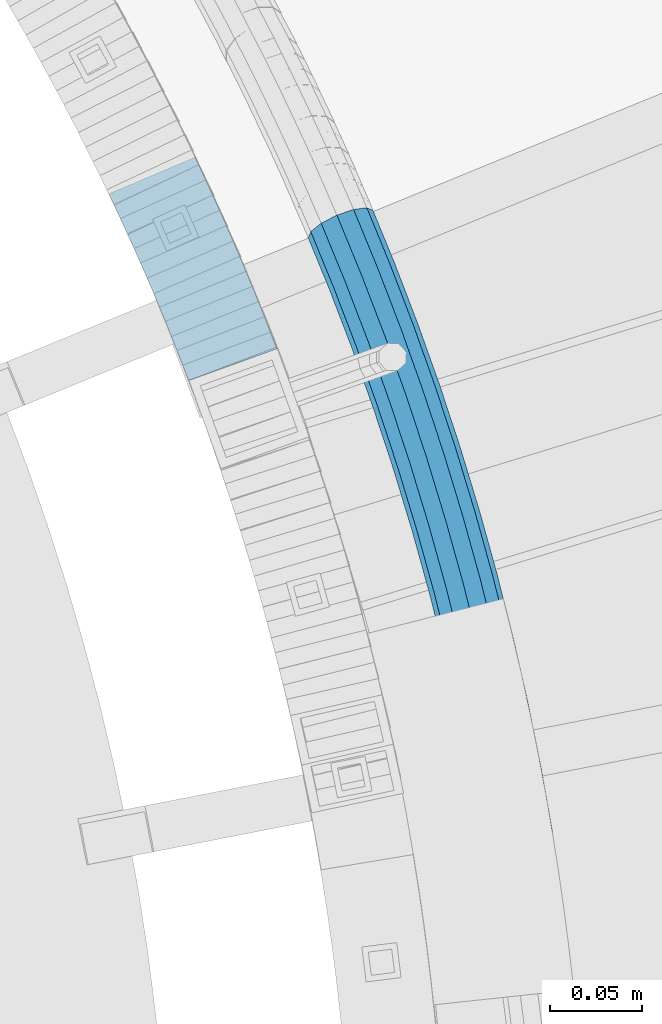
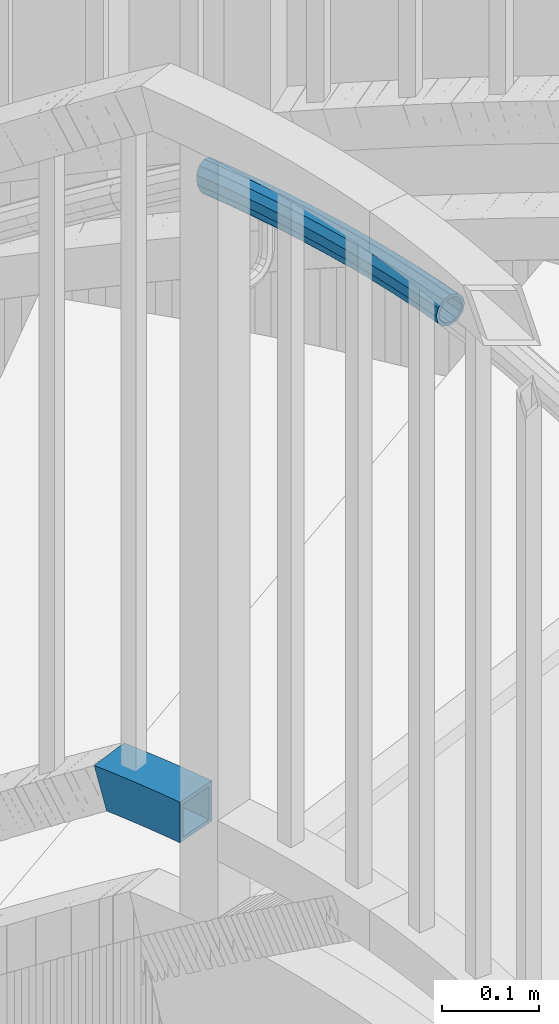
# One storey, part 502 of 975: 2 beams.
"""IFC2X3 building model written with IfcOpenShell, lengths in millimetres."""

from ifc_helpers import new_model, si_unit, frame, origin_with_axes, place, context, subcontext, project, spatial, faceted_brep, material, type_object, element, save


model = new_model("IFC2X3")

# Units and contexts
model_context = context("Model", 3, precision=1e-05, world=origin_with_axes())
body_context = subcontext(model_context, "Body", "Model", "MODEL_VIEW")
ifc_project = project(units=[si_unit("LENGTHUNIT", "METRE", prefix="MILLI"), si_unit("AREAUNIT", "SQUARE_METRE"), si_unit("VOLUMEUNIT", "CUBIC_METRE"), si_unit("MASSUNIT", "GRAM", prefix="KILO"), si_unit("TIMEUNIT", "SECOND"), si_unit("PLANEANGLEUNIT", "RADIAN"), si_unit("SOLIDANGLEUNIT", "STERADIAN"), si_unit("THERMODYNAMICTEMPERATUREUNIT", "DEGREE_CELSIUS"), si_unit("LUMINOUSINTENSITYUNIT", "LUMEN")], contexts=[model_context])

# Site, building, storey
site_placement = place(None, origin_with_axes())
site = spatial("IfcSite", under=ifc_project, at=site_placement, CompositionType="ELEMENT")
building_placement = place(site_placement, origin_with_axes())
building = spatial("IfcBuilding", under=site, at=building_placement, Name="Undefined", CompositionType="ELEMENT")
storey_placement = place(building_placement, origin_with_axes())
storey = spatial("IfcBuildingStorey", under=building, at=storey_placement, Name="Undefined", CompositionType="ELEMENT", Elevation=0.0)

# Beams
ifc_material = material()
beam_type_1 = type_object("IfcBeamType", PredefinedType="NOTDEFINED")
beam_1_placement = place(storey_placement, frame((36096.268932607, 3982.0925191272, 3028.95), z_axis=(0.0, 0.0, 1.0), x_axis=(0.279148057079959, -0.96024807327507, 0.0)))
element("IfcBeam", 1, at=beam_1_placement, inside=storey, type_object=beam_type_1, material=ifc_material, Name="HANDRAIL", context=body_context, shape_type="Brep", body=[
    faceted_brep([(33.3876668180537, 20.1749225351741, -9.52500000000009), (34.0493773826274, 13.2336074557752, -16.4977839420935), (8.77800632553954, 10.5211892533189, -16.4977839420935), (6.00829838439677, 17.2362494753179, -9.52500000000009), (33.1454639414678, 22.7156201899052, 0.0), (3.05124445357887, 19.4855576601331, 0.0), (33.3876668180537, 20.1749225351741, 9.52500000000009), (0.699184745821185, 16.6664134961102, 9.52500000000009), (34.0493773826274, 13.2336074557752, 16.4977839420935), (-0.41764823963058, 9.5342043853525, 16.4977839420935), (34.9532908237879, 3.75159472163068, 19.0500000000002), (-3.63797880709171e-12, 3.63797880709171e-12, 19.0500000000002), (35.8572042649494, -5.73041801250656, 16.4977839420935), (1.84022093912063, -9.38151729624224, 16.4977839420935), (36.5189148295231, -12.6717330918982, 9.52500000000009), (4.60992888025976, -16.0965775182485, 9.52500000000009), (36.761117706109, -15.2124307466365, 0.0), (7.56698281107674, -18.3458857030564, 0.0), (36.5189148295231, -12.6717330918982, -9.52500000000009), (9.91904251883534, -15.5267415390408, -9.52500000000009), (35.8572042649494, -5.73041801250656, -16.4977839420935), (11.0358755042871, -8.39453242827585, -16.4977839420935), (34.9532908237879, 3.75159472163068, -19.0500000000002), (10.618227270902, 1.13967195773876, -19.0500000000002), (69.3074649391092, 16.1725120505725, -16.4977839420935), (69.9858469033625, 6.67170035314484, -19.0500000000002), (70.6642288676157, -2.82911134429742, -16.4977839420935), (71.1608389323883, -9.78418821995729, -9.52500000000009), (71.3426108318708, -12.3299230417178, 0.0), (71.1608389323883, -9.78418821995729, 9.52500000000009), (70.6642288676157, -2.82911134429742, 16.4977839420935), (69.9858469033625, 6.67170035314484, 19.0500000000002), (69.3074649391092, 16.1725120505725, 16.4977839420935), (68.8108548743385, 23.1275889262324, 9.52500000000009), (68.6290829748559, 25.6733237480003, 0.0), (68.8108548743385, 23.1275889262324, -9.52500000000009), (104.294194385069, 25.2378277880198, -9.52500000000009), (104.625423595964, 18.2729155048291, -16.4977839420935), (105.077891112518, 8.75866839083756, -19.0500000000002), (105.530358629074, -0.755578723139479, -16.4977839420935), (105.861587839967, -7.72049100634467, -9.52500000000009), (105.982826145628, -10.2698258371238, 0.0), (105.861587839967, -7.72049100634467, 9.52500000000009), (105.530358629074, -0.755578723139479, 16.4977839420935), (105.077891112518, 8.75866839083756, 19.0500000000002), (104.625423595964, 18.2729155048291, 16.4977839420935), (104.29419438507, 25.2378277880198, 9.52500000000009), (104.172956079408, 27.7871626187989, 0.0), (139.757017472239, 29.0559434649622, 0.0), (139.817653740735, 26.5044478155105, -9.52500000000009), (139.983315107059, 19.5336320659408, -16.4977839420935), (140.209612741879, 10.0113206669193, -19.0500000000002), (140.435910376701, 0.489009267897927, -16.4977839420935), (140.601571743023, -6.48180648167909, -9.52500000000009), (140.662208011521, -9.03330213112349, 0.0), (140.601571743023, -6.48180648167909, 9.52500000000009), (140.435910376701, 0.489009267897927, 16.4977839420935), (140.209612741879, 10.0113206669193, 19.0500000000002), (139.983315107059, 19.5336320659408, 16.4977839420935), (139.817653740735, 26.5044478155105, 9.52500000000009), (175.361178682741, 26.9267339565704, 9.52500000000009), (175.361178682739, 29.4789500144689, 0.0), (175.361178682741, 26.9267339565704, -9.52500000000009), (175.361178682746, 19.9539500144965, -16.4977839420935), (175.361178682757, 10.4289500145242, -19.0500000000002), (175.361178682763, 0.90395001455181, -16.4977839420935), (175.361178682768, -6.06883392752206, -9.52500000000009), (175.361178682771, -8.62104998542054, 0.0), (175.361178682768, -6.06883392752206, 9.52500000000009), (175.361178682763, 0.90395001455181, 16.4977839420935), (175.361178682757, 10.4289500145242, 19.0500000000002), (175.361178682746, 19.9539500144965, 16.4977839420935), (210.739042258436, 19.5336320660281, 16.4977839420935), (210.904703624745, 26.5044478156051, 9.52500000000009), (210.965339893238, 29.0559434650495, 0.0), (210.904703624745, 26.5044478156051, -9.52500000000009), (210.739042258436, 19.5336320660281, -16.4977839420935), (210.512744623631, 10.0113206670139, -19.0500000000002), (210.286446988826, 0.489009267985239, -16.4977839420935), (210.120785622517, -6.48180648159178, -9.52500000000009), (210.060149354023, -9.03330213103618, 0.0), (210.120785622517, -6.48180648159178, 9.52500000000009), (210.286446988826, 0.489009267985239, 16.4977839420935), (210.512744623631, 10.0113206670139, 19.0500000000002), (245.644466252994, 8.75866839102673, 19.0500000000002), (246.096933769533, 18.272915505011, 16.4977839420935), (246.428162980414, 25.237827788209, 9.52500000000009), (246.549401286071, 27.7871626189954, 0.0), (246.428162980414, 25.237827788209, -9.52500000000009), (246.096933769533, 18.272915505011, -16.4977839420935), (245.644466252994, 8.75866839102673, -19.0500000000002), (245.191998736456, -0.75557872295758, -16.4977839420935), (244.860769525577, -7.7204910061555, -9.52500000000009), (244.739531219917, -10.2698258369419, 0.0), (244.860769525577, -7.7204910061555, 9.52500000000009), (245.191998736456, -0.75557872295758, 16.4977839420935), (280.058128497918, -2.82911134402093, 16.4977839420935), (280.736510462153, 6.67170035342133, 19.0500000000002), (281.41489242639, 16.1725120508418, 16.4977839420935), (281.911502491151, 23.1275889265089, 9.52500000000009), (282.093274390627, 25.673323748284, 0.0), (281.911502491151, 23.1275889265089, -9.52500000000009), (281.41489242639, 16.1725120508418, -16.4977839420935), (280.736510462153, 6.67170035342133, -19.0500000000002), (280.058128497918, -2.82911134402093, -16.4977839420935), (279.561518433156, -9.78418821968808, -9.52500000000009), (279.379746533681, -12.3299230414414, 0.0), (279.561518433156, -9.78418821968808, 9.52500000000009), (314.203442536028, -12.671733091549, 9.52500000000009), (314.865153100589, -5.73041801214276, 16.4977839420935), (315.769066541734, 3.75159472200176, 19.0500000000002), (316.672979982877, 13.2336074561463, 16.4977839420935), (317.334690547441, 20.1749225355452, 9.52500000000009), (317.57689342402, 22.7156201902762, 0.0), (317.334690547441, 20.1749225355452, -9.52500000000009), (316.672979982877, 13.2336074561463, -16.4977839420935), (315.769066541734, 3.75159472200176, -19.0500000000002), (314.865153100589, -5.73041801214276, -16.4977839420935), (314.203442536028, -12.671733091549, -9.52500000000009), (313.961239659444, -15.2124307462873, 0.0), (348.464488112119, -18.9157216731255, 0.0), (348.766985233651, -16.3814954997797, 9.52500000000009), (349.593422738822, -9.45786083632993, 16.4977839420935), (350.722357365528, 4.58385329693556e-10, 19.0500000000002), (351.851291992232, 9.4578608372467, 16.4977839420935), (352.677729497404, 16.3814955006965, 9.52500000000009), (352.980226618936, 18.9157216740423, 0.0), (352.677729497404, 16.3814955006965, -9.52500000000009), (351.851291992231, 9.4578608372467, -16.4977839420935), (350.722357365528, 4.58385329693556e-10, -19.0500000000002), (349.593422738822, -9.45786083632993, -16.4977839420935), (348.766985233651, -16.3814954997797, -9.52500000000009), (36.2162275217488, -9.49655638128752, -7.68350000000009), (36.4116045088613, -11.5460524894443, 0.0), (71.0803031390251, -8.65627585204493, 0.0), (70.9336738067759, -6.60271642915177, -7.68350000000009), (105.807872039227, -6.59098361971701, 0.0), (105.710073139326, -4.53452018955431, -7.68350000000009), (140.574706259393, -5.35134172350081, 0.0), (140.525793002802, -3.29313523294695, -7.68350000000009), (175.36117868277, -4.93804998542328, 0.0), (175.361178682766, -2.87926236540079, -7.68350000000009), (210.147651106146, -5.3513417234135, 0.0), (210.196564362732, -3.29313523285964, -7.68350000000009), (244.914485326313, -6.59098361953511, 0.0), (245.01228422621, -4.53452018937242, -7.68350000000009), (279.642054226517, -8.65627585177572, 0.0), (279.788683558763, -6.60271642888983, -7.68350000000009), (314.506129843799, -9.49655638092372, -7.68350000000009), (314.310752856687, -11.5460524890805, 0.0), (348.901009501111, -15.2586821495643, 0.0), (349.145023845813, -13.2144063697342, -7.68350000000009), (279.788683558763, -6.60271642888983, 7.68350000000009), (314.506129843799, -9.49655638092372, 7.68350000000009), (245.01228422621, -4.53452018937242, 7.68350000000009), (210.196564362732, -3.29313523285964, 7.68350000000009), (175.361178682766, -2.87926236540079, 7.68350000000009), (140.525793002802, -3.29313523294695, 7.68350000000009), (105.710073139326, -4.53452018955431, 7.68350000000009), (70.9336738067759, -6.60271642915177, 7.68350000000009), (36.2162275217488, -9.49655638128752, 7.68350000000009), (35.682447666326, -3.89722888389952, 13.3082123799554), (70.5330750211942, -0.992287749453681, 13.3082123799554), (105.442881575875, 1.08384238556027, 13.3082123799554), (140.392159500636, 2.32998947170563, 13.3082123799554), (175.361178682762, 2.7454500145468, 13.3082123799554), (210.330197864889, 2.32998947180022, 13.3082123799554), (245.279475789652, 1.08384238574217, 13.3082123799554), (280.189282344336, -0.99228774918447, 13.3082123799554), (315.039909699211, -3.89722888353572, 13.3082123799554), (280.736510462153, 6.67170035342133, 15.3670000000002), (315.769066541734, 3.75159472200176, 15.3670000000002), (245.644466252994, 8.75866839102673, 15.3670000000002), (210.512744623631, 10.0113206670139, 15.3670000000002), (175.361178682757, 10.4289500145242, 15.3670000000002), (140.209612741879, 10.0113206669193, 15.3670000000002), (105.077891112518, 8.75866839083756, 15.3670000000002), (69.9858469033625, 6.67170035314484, 15.3670000000002), (34.9532908237879, 3.75159472163068, 15.3670000000002), (34.2241339812535, 11.4004183271682, 13.3082123799554), (69.4386187855343, 14.3356884557361, 13.3082123799554), (104.712900649164, 16.4334943961221, 13.3082123799554), (140.027065983124, 17.6926518621258, 13.3082123799554), (175.361178682748, 18.1124500145015, 13.3082123799554), (210.695291382372, 17.6926518622131, 13.3082123799554), (246.009456716336, 16.433494396304, 13.3082123799554), (281.28373857997, 14.3356884560126, 13.3082123799554), (316.498223384257, 11.4004183275392, 13.3082123799554), (281.684337365545, 19.9461171357179, 7.68350000000009), (317.032003239669, 16.99974582492, 7.68350000000009), (246.276648279781, 22.0518569714259, 7.68350000000009), (210.828924884528, 23.3157765668802, 7.68350000000009), (175.361178682743, 23.7371623944346, 7.68350000000009), (139.893432480958, 23.3157765667856, 7.68350000000009), (104.44570908571, 22.0518569712367, 7.68350000000009), (69.038019999949, 19.9461171354342, 7.68350000000009), (33.6903541258307, 16.9997458245562, 7.68350000000009), (33.4949771387164, 19.0492419327129, 0.0), (68.8913906677008, 21.9996765583273, 0.0), (104.34791018581, 24.1083204013921, 0.0), (139.844519224369, 25.3739830573395, 0.0), (175.361178682741, 25.7959500144716, 0.0), (210.877838141114, 25.3739830574268, 0.0), (246.374447179676, 24.1083204015886, 0.0), (281.830966697788, 21.9996765586038, 0.0), (317.227380226779, 19.0492419330767, 0.0), (281.684337365545, 19.9461171357179, -7.68350000000009), (317.032003239669, 16.99974582492, -7.68350000000009), (246.276648279781, 22.0518569714259, -7.68350000000009), (210.828924884528, 23.3157765668802, -7.68350000000009), (175.361178682743, 23.7371623944346, -7.68350000000009), (139.893432480958, 23.3157765667856, -7.68350000000009), (104.44570908571, 22.0518569712367, -7.68350000000009), (69.038019999949, 19.9461171354342, -7.68350000000009), (33.6903541258307, 16.9997458245562, -7.68350000000009), (34.2241339812535, 11.4004183271682, -13.3082123799554), (69.4386187855343, 14.3356884557361, -13.3082123799554), (104.712900649164, 16.4334943961221, -13.3082123799554), (140.027065983124, 17.6926518621258, -13.3082123799554), (175.361178682748, 18.1124500145015, -13.3082123799554), (210.695291382372, 17.6926518622131, -13.3082123799554), (246.009456716336, 16.433494396304, -13.3082123799554), (281.28373857997, 14.3356884560126, -13.3082123799554), (316.498223384257, 11.4004183275392, -13.3082123799554), (280.736510462153, 6.67170035342133, -15.3670000000002), (315.769066541734, 3.75159472200176, -15.3670000000002), (245.644466252994, 8.75866839102673, -15.3670000000002), (210.512744623631, 10.0113206670139, -15.3670000000002), (175.361178682757, 10.4289500145242, -15.3670000000002), (140.209612741879, 10.0113206669193, -15.3670000000002), (105.077891112518, 8.75866839083756, -15.3670000000002), (69.9858469033625, 6.67170035314484, -15.3670000000002), (34.9532908237879, 3.75159472163068, -15.3670000000002), (35.682447666326, -3.89722888389952, -13.3082123799554), (70.5330750211942, -0.992287749453681, -13.3082123799554), (105.442881575875, 1.08384238556027, -13.3082123799554), (140.392159500636, 2.32998947170563, -13.3082123799554), (175.361178682762, 2.7454500145468, -13.3082123799554), (210.330197864889, 2.32998947180022, -13.3082123799554), (245.279475789652, 1.08384238574217, -13.3082123799554), (280.189282344336, -0.99228774918447, -13.3082123799554), (315.039909699211, -3.89722888353572, -13.3082123799554), (349.81168343332, -7.6293410745493, -13.3082123799554), (350.722357365528, 4.58385329693556e-10, -15.3670000000002), (351.633031297737, 7.62934107546607, -13.3082123799554), (352.299690885242, 13.214406370651, -7.68350000000009), (352.543705229946, 15.258682150481, 0.0), (352.299690885242, 13.214406370651, 7.68350000000009), (351.633031297737, 7.62934107546607, 13.3082123799554), (350.722357365528, 4.58385329693556e-10, 15.3670000000002), (349.81168343332, -7.6293410745493, 13.3082123799554), (349.145023845813, -13.2144063697342, 7.68350000000009), (9.92870154237517, -6.66142120295262, -13.3082123799554), (9.0277896007774, -12.4147365523095, -7.68350000000009), (7.13046143651991, -14.6888461779454, 0.0), (4.74510459899466, -12.8744042421968, 7.68350000000009), (2.51087352647119, -7.45758899645443, 13.3082123799554), (1.02642863054643, 0.110168288651039, 15.3670000000002), (0.689525722282269, 7.80109316002927, 13.3082123799554), (1.59043766387913, 13.5544085093788, 7.68350000000009), (3.48776582813844, 15.828518135022, 0.0), (5.8731226656646, 14.0140761992734, -7.68350000000009), (8.10735373818534, 8.5972609535238, -13.3082123799554), (9.59179863411191, 1.02950366843288, -15.3670000000002)], [[[0, 1, 2, 3]], [[4, 0, 3, 5]], [[6, 4, 5, 7]], [[8, 6, 7, 9]], [[10, 8, 9, 11]], [[12, 10, 11, 13]], [[14, 12, 13, 15]], [[16, 14, 15, 17]], [[18, 16, 17, 19]], [[20, 18, 19, 21]], [[22, 20, 21, 23]], [[1, 22, 23, 2]], [[22, 1, 24, 25]], [[20, 22, 25, 26]], [[18, 20, 26, 27]], [[16, 18, 27, 28]], [[14, 16, 28, 29]], [[12, 14, 29, 30]], [[10, 12, 30, 31]], [[8, 10, 31, 32]], [[6, 8, 32, 33]], [[4, 6, 33, 34]], [[0, 4, 34, 35]], [[1, 0, 35, 24]], [[24, 35, 36, 37]], [[25, 24, 37, 38]], [[26, 25, 38, 39]], [[27, 26, 39, 40]], [[28, 27, 40, 41]], [[29, 28, 41, 42]], [[30, 29, 42, 43]], [[31, 30, 43, 44]], [[32, 31, 44, 45]], [[33, 32, 45, 46]], [[34, 33, 46, 47]], [[35, 34, 47, 36]], [[36, 47, 48, 49]], [[37, 36, 49, 50]], [[38, 37, 50, 51]], [[39, 38, 51, 52]], [[40, 39, 52, 53]], [[41, 40, 53, 54]], [[42, 41, 54, 55]], [[43, 42, 55, 56]], [[44, 43, 56, 57]], [[45, 44, 57, 58]], [[46, 45, 58, 59]], [[47, 46, 59, 48]], [[48, 59, 60, 61]], [[49, 48, 61, 62]], [[50, 49, 62, 63]], [[51, 50, 63, 64]], [[52, 51, 64, 65]], [[53, 52, 65, 66]], [[54, 53, 66, 67]], [[55, 54, 67, 68]], [[56, 55, 68, 69]], [[57, 56, 69, 70]], [[58, 57, 70, 71]], [[59, 58, 71, 60]], [[60, 71, 72, 73]], [[61, 60, 73, 74]], [[62, 61, 74, 75]], [[63, 62, 75, 76]], [[64, 63, 76, 77]], [[65, 64, 77, 78]], [[66, 65, 78, 79]], [[67, 66, 79, 80]], [[68, 67, 80, 81]], [[69, 68, 81, 82]], [[70, 69, 82, 83]], [[71, 70, 83, 72]], [[72, 83, 84, 85]], [[73, 72, 85, 86]], [[74, 73, 86, 87]], [[75, 74, 87, 88]], [[76, 75, 88, 89]], [[77, 76, 89, 90]], [[78, 77, 90, 91]], [[79, 78, 91, 92]], [[80, 79, 92, 93]], [[81, 80, 93, 94]], [[82, 81, 94, 95]], [[83, 82, 95, 84]], [[84, 95, 96, 97]], [[85, 84, 97, 98]], [[86, 85, 98, 99]], [[87, 86, 99, 100]], [[88, 87, 100, 101]], [[89, 88, 101, 102]], [[90, 89, 102, 103]], [[91, 90, 103, 104]], [[92, 91, 104, 105]], [[93, 92, 105, 106]], [[94, 93, 106, 107]], [[95, 94, 107, 96]], [[96, 107, 108, 109]], [[97, 96, 109, 110]], [[98, 97, 110, 111]], [[99, 98, 111, 112]], [[100, 99, 112, 113]], [[101, 100, 113, 114]], [[102, 101, 114, 115]], [[103, 102, 115, 116]], [[104, 103, 116, 117]], [[105, 104, 117, 118]], [[106, 105, 118, 119]], [[107, 106, 119, 108]], [[108, 119, 120, 121]], [[109, 108, 121, 122]], [[110, 109, 122, 123]], [[111, 110, 123, 124]], [[112, 111, 124, 125]], [[113, 112, 125, 126]], [[114, 113, 126, 127]], [[115, 114, 127, 128]], [[116, 115, 128, 129]], [[117, 116, 129, 130]], [[118, 117, 130, 131]], [[119, 118, 131, 120]], [[132, 133, 134, 135]], [[135, 134, 136, 137]], [[137, 136, 138, 139]], [[139, 138, 140, 141]], [[141, 140, 142, 143]], [[143, 142, 144, 145]], [[145, 144, 146, 147]], [[148, 149, 150, 151]], [[147, 146, 149, 148]], [[146, 152, 153, 149]], [[144, 154, 152, 146]], [[142, 155, 154, 144]], [[140, 156, 155, 142]], [[138, 157, 156, 140]], [[136, 158, 157, 138]], [[134, 159, 158, 136]], [[133, 160, 159, 134]], [[160, 161, 162, 159]], [[159, 162, 163, 158]], [[158, 163, 164, 157]], [[157, 164, 165, 156]], [[156, 165, 166, 155]], [[155, 166, 167, 154]], [[154, 167, 168, 152]], [[152, 168, 169, 153]], [[168, 170, 171, 169]], [[167, 172, 170, 168]], [[166, 173, 172, 167]], [[165, 174, 173, 166]], [[164, 175, 174, 165]], [[163, 176, 175, 164]], [[162, 177, 176, 163]], [[161, 178, 177, 162]], [[178, 179, 180, 177]], [[177, 180, 181, 176]], [[176, 181, 182, 175]], [[175, 182, 183, 174]], [[174, 183, 184, 173]], [[173, 184, 185, 172]], [[172, 185, 186, 170]], [[170, 186, 187, 171]], [[186, 188, 189, 187]], [[185, 190, 188, 186]], [[184, 191, 190, 185]], [[183, 192, 191, 184]], [[182, 193, 192, 183]], [[181, 194, 193, 182]], [[180, 195, 194, 181]], [[179, 196, 195, 180]], [[196, 197, 198, 195]], [[195, 198, 199, 194]], [[194, 199, 200, 193]], [[193, 200, 201, 192]], [[192, 201, 202, 191]], [[191, 202, 203, 190]], [[190, 203, 204, 188]], [[188, 204, 205, 189]], [[204, 206, 207, 205]], [[203, 208, 206, 204]], [[202, 209, 208, 203]], [[201, 210, 209, 202]], [[200, 211, 210, 201]], [[199, 212, 211, 200]], [[198, 213, 212, 199]], [[197, 214, 213, 198]], [[214, 215, 216, 213]], [[213, 216, 217, 212]], [[212, 217, 218, 211]], [[211, 218, 219, 210]], [[210, 219, 220, 209]], [[209, 220, 221, 208]], [[208, 221, 222, 206]], [[206, 222, 223, 207]], [[222, 224, 225, 223]], [[221, 226, 224, 222]], [[220, 227, 226, 221]], [[219, 228, 227, 220]], [[218, 229, 228, 219]], [[217, 230, 229, 218]], [[216, 231, 230, 217]], [[215, 232, 231, 216]], [[232, 233, 234, 231]], [[231, 234, 235, 230]], [[230, 235, 236, 229]], [[229, 236, 237, 228]], [[228, 237, 238, 227]], [[227, 238, 239, 226]], [[226, 239, 240, 224]], [[224, 240, 241, 225]], [[225, 241, 242, 243]], [[223, 225, 243, 244]], [[207, 223, 244, 245]], [[205, 207, 245, 246]], [[189, 205, 246, 247]], [[187, 189, 247, 248]], [[171, 187, 248, 249]], [[169, 171, 249, 250]], [[153, 169, 250, 251]], [[149, 153, 251, 150]], [[130, 129, 128, 127, 126, 125, 124, 123, 122, 121, 120, 131], [250, 249, 248, 247, 246, 245, 244, 243, 242, 151, 150, 251]], [[241, 148, 151, 242]], [[240, 147, 148, 241]], [[239, 145, 147, 240]], [[238, 143, 145, 239]], [[237, 141, 143, 238]], [[236, 139, 141, 237]], [[235, 137, 139, 236]], [[234, 135, 137, 235]], [[233, 132, 135, 234]], [[132, 233, 252, 253]], [[133, 132, 253, 254]], [[160, 133, 254, 255]], [[161, 160, 255, 256]], [[178, 161, 256, 257]], [[179, 178, 257, 258]], [[196, 179, 258, 259]], [[197, 196, 259, 260]], [[214, 197, 260, 261]], [[215, 214, 261, 262]], [[232, 215, 262, 263]], [[233, 232, 263, 252]], [[17, 15, 13, 11, 9, 7, 5, 3, 2, 23, 21, 19], [262, 261, 260, 259, 258, 257, 256, 255, 254, 253, 252, 263]]]),
])
beam_type_2 = type_object("IfcBeamType", Name="HSS2X2X.188_TUBES", PredefinedType="NOTDEFINED")
beam_2_placement = place(storey_placement, frame((35985.6127835684, 4025.34905878355, 2298.70000076294), z_axis=(0.0, 0.0, 1.0), x_axis=(0.392437318127493, -0.919778751298866, 0.0)))
element("IfcBeam", 2, at=beam_2_placement, inside=storey, type_object=beam_type_2, material=ifc_material, Name="HANDRAIL", ObjectType="HSS2X2X.188_TUBES", context=body_context, shape_type="Brep", body=[
    faceted_brep([(112.111922654291, -23.4524864620107, 25.4000000000001), (112.111922654291, -23.4524864620107, -25.4000000000001), (127.919743483888, -23.906299729395, -25.4000000000001), (127.919743483888, -23.906299729395, 25.4000000000001), (96.2999337819492, -23.1801745759076, 25.4000000000001), (96.2999337819492, -23.1801745759076, -25.4000000000001), (80.4858607509032, -23.0893999594555, 25.4000000000001), (80.4858607509032, -23.0893999594555, -25.4000000000001), (64.6717877198553, -23.180174575944, 25.4000000000001), (64.6717877198553, -23.180174575944, -25.4000000000001), (48.8597988475158, -23.4524864620907, 25.4000000000001), (48.8597988475158, -23.4524864620907, -25.4000000000001), (31.3027556717971, 26.8635754049901, 25.4000000000001), (31.3027556717971, 26.8635754049901, 2.48440740747264), (24.2666781223488, 26.5807109508241, 25.4000000000001), (47.6935225274156, 27.3341239734873, 25.4000000000001), (47.6935225274156, 27.3341239734873, -25.4000000000001), (39.8641239065328, 27.1093564354087, -25.4000000000001), (64.0886111309537, 27.6164779225801, 25.4000000000001), (64.0886111309537, 27.6164779225801, -25.4000000000001), (80.485860750854, 27.7106000404528, 25.4000000000001), (80.485860750854, 27.7106000404528, -25.4000000000001), (96.8831103707562, 27.6164779226165, 25.4000000000001), (96.8831103707562, 27.6164779226165, -25.4000000000001), (113.278198974298, 27.3341239735673, 25.4000000000001), (113.278198974298, 27.3341239735673, -25.4000000000001), (129.668965829913, 26.8635754051138, 25.4000000000001), (129.668965829913, 26.8635754051138, -25.4000000000001), (137.056283625601, 26.5665903873669, 25.4000000000001), (137.056283625601, 26.5665903873669, -25.4000000000001), (39.6832398393526, -23.7159284805821, -25.4000000000001), (134.143827794955, -24.1565204239305, -25.4000000000001), (134.143827794955, -24.1565204239305, 25.4000000000001), (24.0857150910451, -24.2667615139362, 25.4000000000001), (33.0519780179184, -23.9062997295259, 25.4000000000001), (33.0519780179184, -23.9062997295259, -3.80195618449716), (31.4667452667472, 22.1038996111311, 20.6374999999998), (25.7120062173963, 21.8725475390893, 20.6374999999998), (31.4667452667472, 22.1038996111311, 1.89506082072558), (32.88798842297, -19.1466239356669, 20.6374999999998), (32.88798842297, -19.1466239356669, -3.21260959774963), (25.5649737544627, -19.4410238385244, 20.6374999999998), (112.221261059289, -18.6912417336789, -20.6374999999998), (112.221261059289, -18.6912417336789, 20.6374999999998), (128.083733078827, -19.1466239355286, 20.6374999999998), (128.083733078827, -19.1466239355286, -20.6374999999998), (96.3546065871487, -18.4179884041732, -20.6374999999998), (96.3546065871487, -18.4179884041732, 20.6374999999998), (80.4858607508995, -18.3268999594584, -20.6374999999998), (80.4858607508995, -18.3268999594584, 20.6374999999998), (64.6171149146448, -18.4179884042169, -20.6374999999998), (64.6171149146448, -18.4179884042169, 20.6374999999998), (48.7504604425085, -18.6912417337517, -20.6374999999998), (48.7504604425085, -18.6912417337517, 20.6374999999998), (38.2379641640237, -18.9930360377548, -20.6374999999998), (38.3849324686053, 22.3025079564832, -20.6374999999998), (47.8028609324228, 22.5728792451482, -20.6374999999998), (47.8028609324228, 22.5728792451482, 20.6374999999998), (64.1432839361605, 22.8542917508385, -20.6374999999998), (64.1432839361605, 22.8542917508385, 20.6374999999998), (80.4858607508595, 22.9481000404558, -20.6374999999998), (80.4858607508595, 22.9481000404558, 20.6374999999998), (96.8284375655567, 22.8542917508821, -20.6374999999998), (96.8284375655567, 22.8542917508821, 20.6374999999998), (113.168860569298, 22.5728792452355, -20.6374999999998), (113.168860569298, 22.5728792452355, 20.6374999999998), (129.504976234975, 22.103899611262, -20.6374999999998), (129.504976234975, 22.103899611262, 20.6374999999998), (136.783240891478, 21.8112987488057, 20.6374999999998), (134.416870529078, -19.4012287853766, 20.6374999999998), (134.416870529078, -19.4012287853766, -20.6374999999998), (136.783240891478, 21.8112987488057, -20.6374999999998)], [[[0, 1, 2, 3]], [[4, 5, 1, 0]], [[6, 7, 5, 4]], [[8, 9, 7, 6]], [[10, 11, 9, 8]], [[12, 13, 14]], [[12, 15, 16, 17, 13]], [[16, 15, 18, 19]], [[19, 18, 20, 21]], [[21, 20, 22, 23]], [[23, 22, 24, 25]], [[25, 24, 26, 27]], [[27, 26, 28, 29]], [[2, 1, 5, 7, 9, 11, 30, 17, 16, 19, 21, 23, 25, 27, 29, 31]], [[3, 2, 31, 32]], [[26, 24, 22, 20, 18, 15, 12, 14, 33, 34, 10, 8, 6, 4, 0, 3, 32, 28]], [[34, 33, 35]], [[11, 10, 34, 35, 30]], [[36, 37, 38]], [[39, 40, 41]], [[42, 43, 44, 45]], [[46, 47, 43, 42]], [[48, 49, 47, 46]], [[50, 51, 49, 48]], [[52, 53, 51, 50]], [[39, 53, 52, 54, 40]], [[33, 14, 13, 17, 30, 35], [38, 37, 41, 40, 54, 55]], [[56, 57, 36, 38, 55]], [[57, 56, 58, 59]], [[59, 58, 60, 61]], [[61, 60, 62, 63]], [[63, 62, 64, 65]], [[65, 64, 66, 67]], [[44, 43, 47, 49, 51, 53, 39, 41, 37, 36, 57, 59, 61, 63, 65, 67, 68, 69]], [[45, 44, 69, 70]], [[66, 64, 62, 60, 58, 56, 55, 54, 52, 50, 48, 46, 42, 45, 70, 71]], [[67, 66, 71, 68]], [[31, 29, 28, 32], [70, 69, 68, 71]]]),
])

save(model, "model.ifc")
